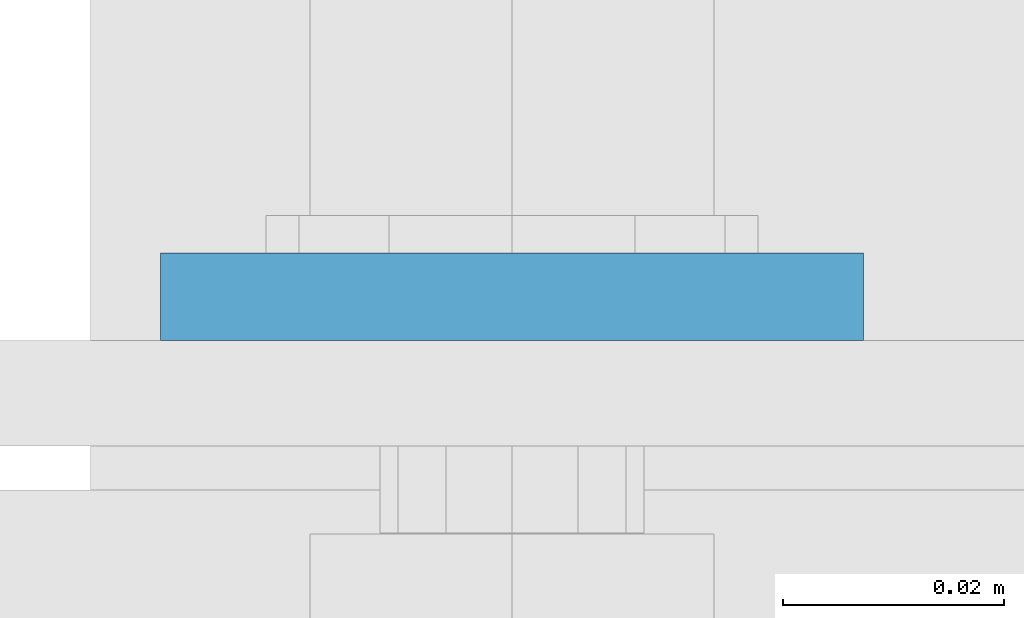
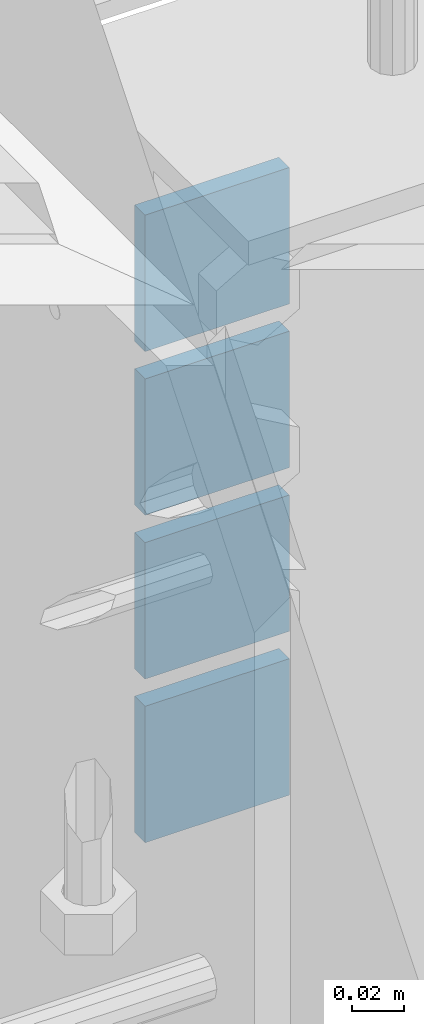
# One storey, part 932 of 975: 4 plates.
"""IFC2X3 building model written with IfcOpenShell, lengths in millimetres."""

from ifc_helpers import new_model, si_unit, frame, origin_with_axes, place, context, subcontext, project, spatial, faceted_brep, material, type_object, element, save


model = new_model("IFC2X3")

# Units and contexts
model_context = context("Model", 3, precision=1e-05, world=origin_with_axes())
body_context = subcontext(model_context, "Body", "Model", "MODEL_VIEW")
ifc_project = project(units=[si_unit("LENGTHUNIT", "METRE", prefix="MILLI"), si_unit("AREAUNIT", "SQUARE_METRE"), si_unit("VOLUMEUNIT", "CUBIC_METRE"), si_unit("MASSUNIT", "GRAM", prefix="KILO"), si_unit("TIMEUNIT", "SECOND"), si_unit("PLANEANGLEUNIT", "RADIAN"), si_unit("SOLIDANGLEUNIT", "STERADIAN"), si_unit("THERMODYNAMICTEMPERATUREUNIT", "DEGREE_CELSIUS"), si_unit("LUMINOUSINTENSITYUNIT", "LUMEN")], contexts=[model_context])

# Site, building, storey
site_placement = place(None, origin_with_axes())
site = spatial("IfcSite", under=ifc_project, at=site_placement, CompositionType="ELEMENT")
building_placement = place(site_placement, origin_with_axes())
building = spatial("IfcBuilding", under=site, at=building_placement, Name="Undefined", CompositionType="ELEMENT")
storey_placement = place(building_placement, origin_with_axes())
storey = spatial("IfcBuildingStorey", under=building, at=storey_placement, Name="Undefined", CompositionType="ELEMENT", Elevation=0.0)

# Plates
ifc_material = material(Name="STEEL/A36")
plate_type = type_object("IfcPlateType", PredefinedType="NOTDEFINED")
for number, where, z_axis, x_axis, name in (
    (1, (2352.675, 13409.6125, 3663.95), (1.0, 0.0, 0.0), (0.0, 0.0, -1.0), "PLATE"),
    (2, (2352.675, 13409.6125, 3740.15), (1.0, 0.0, 0.0), (0.0, 0.0, -1.0), "PLATE"),
    (3, (2352.675, 13409.6125, 3816.35), (1.0, 0.0, 0.0), (0.0, 0.0, -1.0), "PLATE"),
    (4, (2352.675, 13409.6125, 3892.55), (1.0, 0.0, 0.0), (0.0, 0.0, -1.0), "PLATE"),
):
    element("IfcPlate", number, at=place(storey_placement, frame(where, z_axis=z_axis, x_axis=x_axis)), inside=storey, type_object=plate_type, material=ifc_material, Name=name, context=body_context, shape_type="Brep", body=[
        faceted_brep([(0.0, -3.96900000000005, 0.0), (0.0, -3.96900000000005, 63.5), (0.0, 3.96900000000005, 63.5), (0.0, 3.96900000000005, 0.0), (63.5, -3.96900000000005, 63.5), (63.5, 3.96900000000005, 63.5), (63.5, -3.96900000000005, 0.0), (63.5, 3.96900000000005, 0.0)], [[[0, 1, 2, 3]], [[1, 4, 5, 2]], [[4, 6, 7, 5]], [[6, 0, 3, 7]], [[5, 7, 3, 2]], [[6, 4, 1, 0]]]),
    ])

save(model, "model.ifc")
